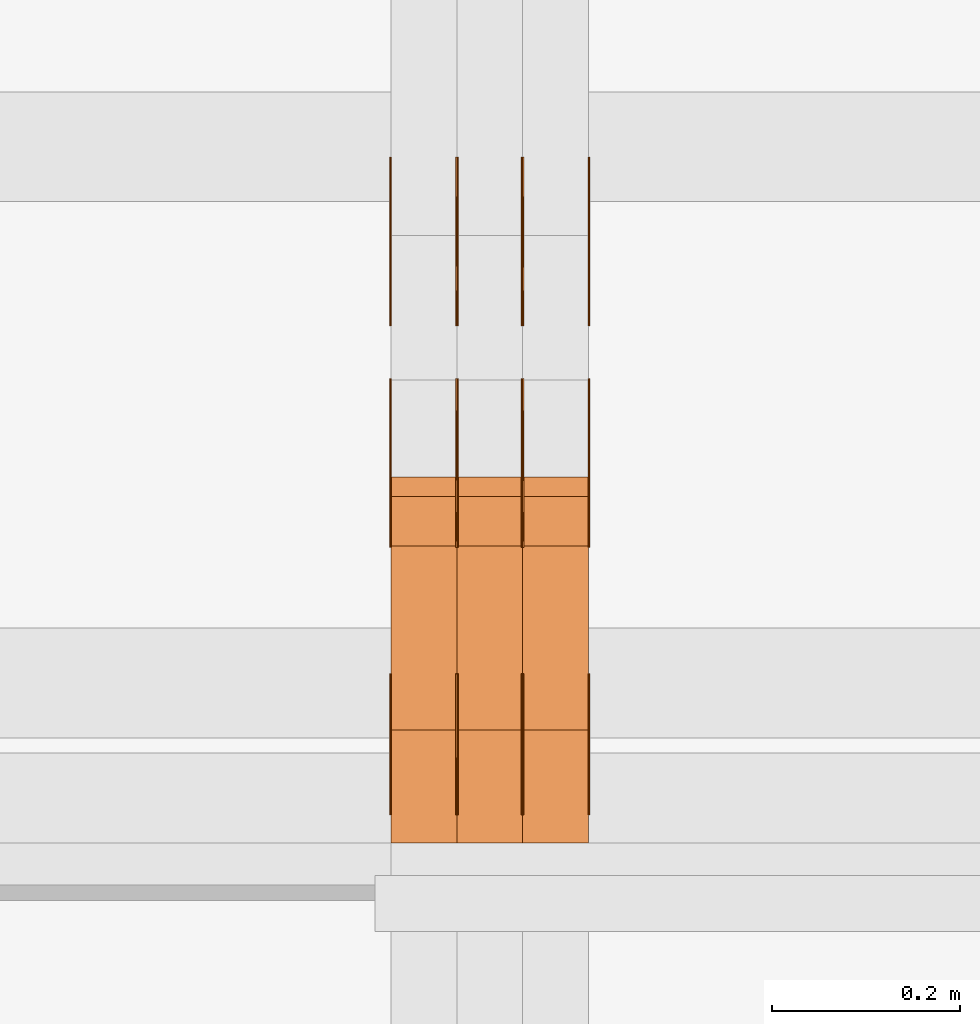
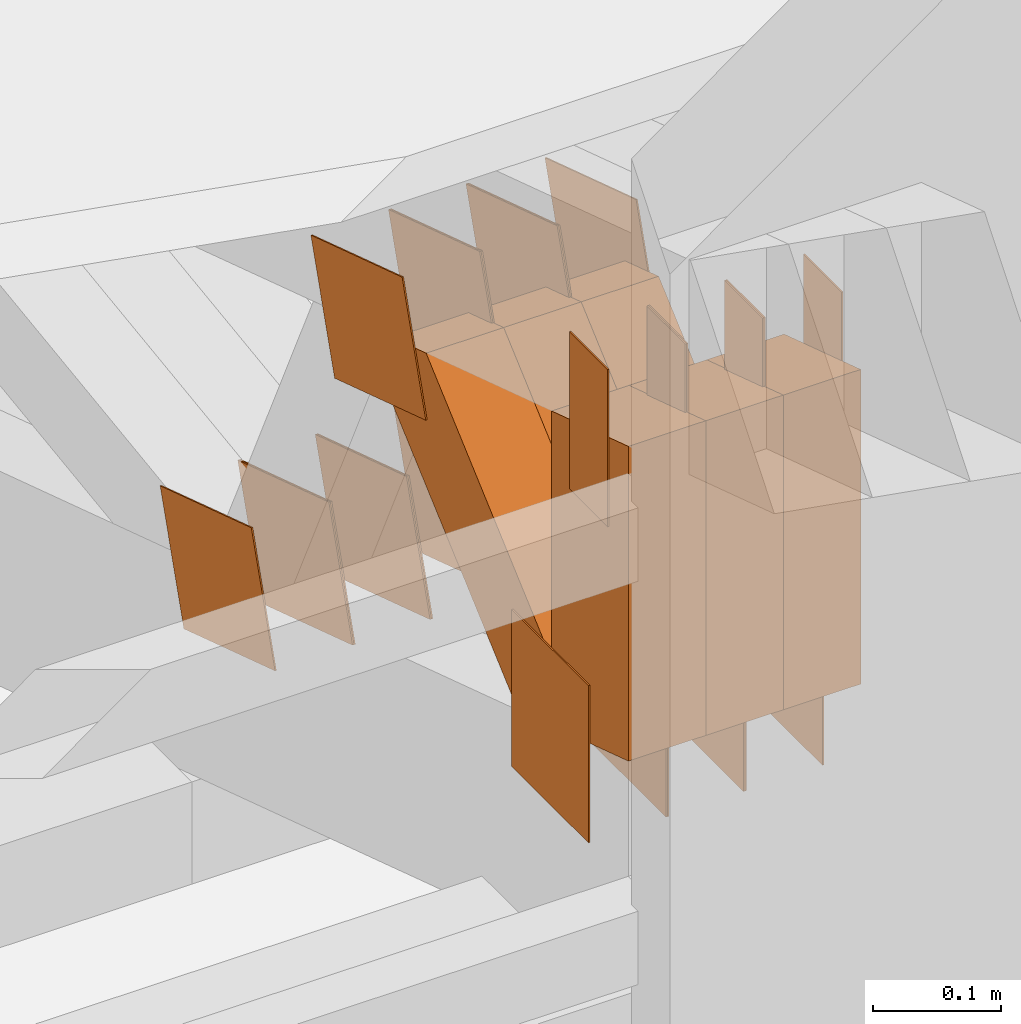
# One storey, part 161 of 385: 30 proxies.
"""IFC2X3 building model written with IfcOpenShell, lengths in millimetres."""

import ifcopenshell
import ifcopenshell.guid

model = None  # the IFC model being written
_history = None  # IfcOwnerHistory: only IFC2X3 demands one
_inside = {}  # id of a spatial element -> (the spatial element, [elements in it])
_under = {}  # id of a project, library or spatial element -> (it, [spatial elements below it])
_declared = {}  # id of a project -> (the project, [libraries it declares])
_typed = {}  # id of a type object -> (the type object, [elements of that type])
_made_of = {}  # id of a material, layer set ... -> (it, [elements and type objects made of it])


def new_model(schema):
    """Start an empty IFC model of exactly this schema.

    Asked for "IFC4X3", IfcOpenShell would pick the latest addendum, in which some entities
    have other attributes; the version numbers below select the first issue.
    IFC2X3 requires an IfcOwnerHistory on every rooted entity: one is made here for all.
    """
    global model, _history
    if schema == "IFC4X3":
        model = ifcopenshell.file(schema_version=(4, 3, 0, 0))
    else:
        model = ifcopenshell.file(schema=schema)
    _inside.clear()
    _under.clear()
    _declared.clear()
    _typed.clear()
    _made_of.clear()
    _history = None
    if model.schema == "IFC2X3":
        org = make("IfcOrganization", Name="unknown")
        user = make(
            "IfcPersonAndOrganization",
            ThePerson=make("IfcPerson", FamilyName="unknown"),
            TheOrganization=org,
        )
        app = make(
            "IfcApplication",
            ApplicationDeveloper=org,
            Version="unknown",
            ApplicationFullName="unknown",
            ApplicationIdentifier="unknown",
        )
        _history = make(
            "IfcOwnerHistory",
            OwningUser=user,
            OwningApplication=app,
            ChangeAction="ADDED",
            CreationDate=0,
        )
    return model


def make(cls, **values):
    """One entity of the class cls with the attributes given. An attribute that is None is left unset."""
    return model.create_entity(
        cls, **{name: value for name, value in values.items() if value is not None}
    )


def entity(cls, *values):
    """Any entity or typed value of the class cls, its attributes in the order of the schema. None: left unset."""
    e = model.create_entity(cls)
    for i, value in enumerate(values):
        if value is not None:
            e[i] = value
    return e


def rooted(cls, **values):
    """An entity with a GlobalId (a new one), such as an element, a storey or a relation."""
    return make(cls, GlobalId=ifcopenshell.guid.new(), OwnerHistory=_history, **values)


def si_unit(unit_type, name, prefix=None):
    """IfcSIUnit, for example si_unit("LENGTHUNIT", "METRE", prefix="MILLI")."""
    return make("IfcSIUnit", UnitType=unit_type, Prefix=prefix, Name=name)


def converted_unit(unit_type, name, factor, base, dimensions=None, offset=None):
    """IfcConversionBasedUnit, such as the inch: factor (a typed value) times the base unit."""
    return make(
        "IfcConversionBasedUnit"
        if offset is None
        else "IfcConversionBasedUnitWithOffset",
        ConversionOffset=offset,
        Dimensions=None
        if dimensions is None
        else entity("IfcDimensionalExponents", *dimensions),
        UnitType=unit_type,
        Name=name,
        ConversionFactor=make(
            "IfcMeasureWithUnit", ValueComponent=factor, UnitComponent=base
        ),
    )


def derived_unit(unit_type, elements):
    """IfcDerivedUnit: a product of units, each with its exponent."""
    return make(
        "IfcDerivedUnit",
        Elements=[
            make("IfcDerivedUnitElement", Unit=unit, Exponent=power)
            for unit, power in elements
        ],
        UnitType=unit_type,
    )


def assignment(units):
    """IfcUnitAssignment: the units of a project."""
    return None if units is None else make("IfcUnitAssignment", Units=units)


def point(xyz):
    """IfcCartesianPoint."""
    return None if xyz is None else make("IfcCartesianPoint", Coordinates=xyz)


def direction(xyz):
    """IfcDirection."""
    return None if xyz is None else make("IfcDirection", DirectionRatios=xyz)


def frame(location, z_axis=None, x_axis=None):
    """IfcAxis2Placement3D, a coordinate frame: its origin and axes. An axis left out is left unset."""
    return make(
        "IfcAxis2Placement3D",
        Location=point(location),
        Axis=direction(z_axis),
        RefDirection=direction(x_axis),
    )


def frame_2d(location, x_axis=None):
    """IfcAxis2Placement2D, a coordinate frame in the plane: its origin and x axis."""
    return make(
        "IfcAxis2Placement2D", Location=point(location), RefDirection=direction(x_axis)
    )


def origin():
    """The frame at (0, 0, 0) with its axes left unset."""
    return frame((0.0, 0.0, 0.0))


def origin_2d_with_axis():
    """The frame at (0, 0) in the plane with the x axis (1, 0) written out."""
    return frame_2d((0.0, 0.0), x_axis=(1.0, 0.0))


def place(relative_to, where):
    """IfcLocalPlacement: puts the frame where relative to a parent placement (None: the world)."""
    return make(
        "IfcLocalPlacement", PlacementRelTo=relative_to, RelativePlacement=where
    )


def context(
    kind, dimensions, precision=None, world=None, true_north=None, identifier=None
):
    """IfcGeometricRepresentationContext, for example the 3D "Model" context."""
    return make(
        "IfcGeometricRepresentationContext",
        ContextIdentifier=identifier,
        ContextType=kind,
        CoordinateSpaceDimension=dimensions,
        Precision=precision,
        WorldCoordinateSystem=world,
        TrueNorth=true_north,
    )


def subcontext(parent, identifier, kind, view, scale=None):
    """IfcGeometricRepresentationSubContext, for example "Body" below "Model"."""
    return make(
        "IfcGeometricRepresentationSubContext",
        ContextIdentifier=identifier,
        ContextType=kind,
        ParentContext=parent,
        TargetScale=scale,
        TargetView=view,
    )


def project(units=None, contexts=None):
    """IfcProject with its units and contexts."""
    return rooted(
        "IfcProject",
        Name="project",
        RepresentationContexts=contexts,
        UnitsInContext=assignment(units),
    )


def spatial(cls, under=None, at=None, **own):
    """A site, building, storey or space (cls), placed at a placement, below another one or the project."""
    s = rooted(cls, ObjectPlacement=at, **own)
    if under is not None:
        _under.setdefault(under.id(), (under, []))[1].append(s)
    return s


def polyline(points):
    """IfcPolyline through the points."""
    return make("IfcPolyline", Points=[point(p) for p in points])


def profile(cls, at=None, kind="AREA", **sizes):
    """A parametric profile (cls). Its sizes go by their IFC names, for example OverallWidth=200.0."""
    return make(cls, ProfileType=kind, Position=at, **sizes)


def rectangle(**sizes):
    """IfcRectangleProfileDef."""
    return profile("IfcRectangleProfileDef", **sizes)


def outline(outer, holes=None, kind="AREA"):
    """IfcArbitraryClosedProfileDef: a profile drawn as a closed curve; with holes, ...WithVoids."""
    if holes is None:
        return make("IfcArbitraryClosedProfileDef", ProfileType=kind, OuterCurve=outer)
    return make(
        "IfcArbitraryProfileDefWithVoids",
        ProfileType=kind,
        OuterCurve=outer,
        InnerCurves=holes,
    )


def extrude(swept, where, along, depth):
    """IfcExtrudedAreaSolid: the profile swept, set in the frame where, extruded along a direction by depth."""
    return make(
        "IfcExtrudedAreaSolid",
        SweptArea=swept,
        Position=where,
        ExtrudedDirection=direction(along),
        Depth=depth,
    )


def shape(context_of_items, identifier, shape_type, items):
    """IfcShapeRepresentation: the items that make up one representation, for example the "Body"."""
    return make(
        "IfcShapeRepresentation",
        ContextOfItems=context_of_items,
        RepresentationIdentifier=identifier,
        RepresentationType=shape_type,
        Items=items,
    )


def source(mapping_origin, context_of_items, identifier, shape_type, items):
    """IfcRepresentationMap: a shape defined once, which mapped items show again and again."""
    return make(
        "IfcRepresentationMap",
        MappingOrigin=mapping_origin,
        MappedRepresentation=shape(context_of_items, identifier, shape_type, items),
    )


def transform(
    local_origin,
    x_axis=None,
    y_axis=None,
    z_axis=None,
    scale=None,
    scale2=None,
    scale3=None,
    uniform=True,
):
    """IfcCartesianTransformationOperator3D, or its non-uniform kind. x_axis, y_axis, z_axis: its Axis1, 2, 3."""
    if uniform:
        return make(
            "IfcCartesianTransformationOperator3D",
            Axis1=direction(x_axis),
            Axis2=direction(y_axis),
            LocalOrigin=point(local_origin),
            Scale=scale,
            Axis3=direction(z_axis),
        )
    return make(
        "IfcCartesianTransformationOperator3DnonUniform",
        Axis1=direction(x_axis),
        Axis2=direction(y_axis),
        LocalOrigin=point(local_origin),
        Scale=scale,
        Axis3=direction(z_axis),
        Scale2=scale2,
        Scale3=scale3,
    )


def mapped(mapping_source, mapping_target):
    """IfcMappedItem: shows the shape of a source again, moved by a transform."""
    return make(
        "IfcMappedItem", MappingSource=mapping_source, MappingTarget=mapping_target
    )


def material(Name=None, Category=None):
    """IfcMaterial."""
    return make("IfcMaterial", Name=Name, Category=Category)


def made_of(thing, what):
    """Note that an element or type object is made of a material, layer set ...; save() writes the relation."""
    if what is not None:
        _made_of.setdefault(what.id(), (what, []))[1].append(thing)
    return thing


def type_object(cls, material=None, **own):
    """A type object (cls), such as IfcWallType, which elements share."""
    return made_of(rooted(cls, **own), material)


def type_shapes(of_type, sources):
    """Give a type object the sources (RepresentationMaps) that its elements show as mapped items."""
    of_type.RepresentationMaps = sources


def element(
    cls,
    number,
    at=None,
    inside=None,
    cuts=None,
    type_object=None,
    material=None,
    context=None,
    identifier="Body",
    shape_type=None,
    held_by="IfcProductDefinitionShape",
    body=None,
    shapes=None,
    **own,
):
    """One element of the class cls, such as IfcWall. Its Tag is "e" and its number.

    at: its placement. inside: the storey or other place that contains it. cuts: it is an
    opening in that element (IfcRelVoidsElement). A single representation is given by context,
    identifier, shape_type and body (its items); several are given by shapes. held_by: the class
    of the entity that holds the representations. save() writes the other relations.
    """
    e = rooted(cls, Tag="e%d" % number, ObjectPlacement=at, **own)
    if body is not None:
        shapes = [shape(context, identifier, shape_type, body)]
    if shapes is not None:
        e.Representation = make(held_by, Representations=shapes)
    if inside is not None:
        _inside.setdefault(inside.id(), (inside, []))[1].append(e)
    if cuts is not None:
        rooted(
            "IfcRelVoidsElement", RelatingBuildingElement=cuts, RelatedOpeningElement=e
        )
    if type_object is not None:
        _typed.setdefault(type_object.id(), (type_object, []))[1].append(e)
    return made_of(e, material)


def aggregate(whole, parts):
    """IfcRelAggregates: a whole, such as a stair, and the parts it consists of."""
    return rooted("IfcRelAggregates", RelatingObject=whole, RelatedObjects=parts)


def save(model, path):
    """Write the relations noted so far, then the file.

    IfcRelAggregates (storeys below a building ...), IfcRelContainedInSpatialStructure (elements
    in a storey), IfcRelDefinesByType, IfcRelAssociatesMaterial and IfcRelDeclares: one each for
    every whole, place, type object, material and project.
    """
    for whole, parts in _under.values():
        aggregate(whole, parts)
    for where, things in _inside.values():
        rooted(
            "IfcRelContainedInSpatialStructure",
            RelatedElements=things,
            RelatingStructure=where,
        )
    for kind, things in _typed.values():
        rooted("IfcRelDefinesByType", RelatedObjects=things, RelatingType=kind)
    for what, things in _made_of.values():
        rooted("IfcRelAssociatesMaterial", RelatedObjects=things, RelatingMaterial=what)
    for by, libraries in _declared.values():
        rooted("IfcRelDeclares", RelatingContext=by, RelatedDefinitions=libraries)
    model.write(path)


model = new_model("IFC2X3")

# Units and contexts
model_context = context("Model", 3, precision=0.01, world=origin(), true_north=direction((6.12303176911189e-17, 1.0)))
body_context = subcontext(model_context, "Body", "Model", "MODEL_VIEW")
ifc_project = project(units=[si_unit("LENGTHUNIT", "METRE", prefix="MILLI"), si_unit("AREAUNIT", "SQUARE_METRE"), si_unit("VOLUMEUNIT", "CUBIC_METRE"), converted_unit("PLANEANGLEUNIT", "DEGREE", entity("IfcRatioMeasure", 0.0174532925199433), si_unit("PLANEANGLEUNIT", "RADIAN"), dimensions=[0, 0, 0, 0, 0, 0, 0]), si_unit("MASSUNIT", "GRAM", prefix="KILO"), derived_unit("MASSDENSITYUNIT", [(si_unit("MASSUNIT", "GRAM", prefix="KILO"), 1), (si_unit("LENGTHUNIT", "METRE"), -3)]), si_unit("TIMEUNIT", "SECOND"), si_unit("FREQUENCYUNIT", "HERTZ"), si_unit("THERMODYNAMICTEMPERATUREUNIT", "DEGREE_CELSIUS"), derived_unit("THERMALTRANSMITTANCEUNIT", [(si_unit("MASSUNIT", "GRAM", prefix="KILO"), 1), (si_unit("THERMODYNAMICTEMPERATUREUNIT", "KELVIN"), -1), (si_unit("TIMEUNIT", "SECOND"), -3)]), derived_unit("VOLUMETRICFLOWRATEUNIT", [(si_unit("LENGTHUNIT", "METRE"), 3), (si_unit("TIMEUNIT", "SECOND"), -1)]), si_unit("ELECTRICCURRENTUNIT", "AMPERE"), si_unit("ELECTRICVOLTAGEUNIT", "VOLT"), si_unit("POWERUNIT", "WATT"), si_unit("FORCEUNIT", "NEWTON", prefix="KILO"), si_unit("ILLUMINANCEUNIT", "LUX"), si_unit("LUMINOUSFLUXUNIT", "LUMEN"), si_unit("LUMINOUSINTENSITYUNIT", "CANDELA"), derived_unit("USERDEFINED", [(si_unit("MASSUNIT", "GRAM", prefix="KILO"), -1), (si_unit("LENGTHUNIT", "METRE"), -2), (si_unit("TIMEUNIT", "SECOND"), 3), (si_unit("LUMINOUSFLUXUNIT", "LUMEN"), 1)]), derived_unit("LINEARVELOCITYUNIT", [(si_unit("LENGTHUNIT", "METRE"), 1), (si_unit("TIMEUNIT", "SECOND"), -1)]), si_unit("PRESSUREUNIT", "PASCAL"), derived_unit("USERDEFINED", [(si_unit("LENGTHUNIT", "METRE"), -2), (si_unit("MASSUNIT", "GRAM", prefix="KILO"), 1), (si_unit("TIMEUNIT", "SECOND"), -2)])], contexts=[model_context])

# Site, building, storey
site_placement = place(None, origin())
site = spatial("IfcSite", under=ifc_project, at=site_placement, CompositionType="ELEMENT")
building_placement = place(site_placement, origin())
building = spatial("IfcBuilding", under=site, at=building_placement, CompositionType="ELEMENT")
storey_placement = place(building_placement, origin())
storey = spatial("IfcBuildingStorey", under=building, at=storey_placement, Name="Default", CompositionType="ELEMENT", Elevation=0.0)

# Proxies
ifc_material_1 = material(Name="IfcSurfaceStyle #308674")
building_element_proxy_type_1 = type_object("IfcBuildingElementProxyType", PredefinedType="NOTDEFINED", material=ifc_material_1)
shared_shape_1 = source(origin(), body_context, "Body", "SweptSolid", [
    extrude(rectangle(XDim=150.0, YDim=120.0, at=origin_2d_with_axis()), frame((75.0, 60.0, 0.0), z_axis=(0.0, 0.0, 1.0), x_axis=(-1.0, 0.0, 0.0)), (0.0, 0.0, 1.0), 1.3),
])
type_shapes(building_element_proxy_type_1, [shared_shape_1])
proxy_1_placement = place(building_placement, frame((24386.3, 15840.0, 3652.70166015625), z_axis=(-1.0, 0.0, 0.0), x_axis=(0.0, 0.0, -1.0)))
element("IfcBuildingElementProxy", 1, at=proxy_1_placement, inside=storey, type_object=building_element_proxy_type_1, material=ifc_material_1, context=body_context, shape_type="MappedRepresentation", body=[
    mapped(shared_shape_1, transform((0.0, 0.0, 0.0), scale=1.0)),
])
ifc_material_2 = material(Name="IfcSurfaceStyle #308617")
building_element_proxy_type_2 = type_object("IfcBuildingElementProxyType", PredefinedType="NOTDEFINED", material=ifc_material_2)
shared_shape_2 = source(origin(), body_context, "Body", "SweptSolid", [
    extrude(rectangle(XDim=150.0, YDim=120.0, at=origin_2d_with_axis()), frame((75.0, 60.0, 0.0), z_axis=(0.0, 0.0, 1.0), x_axis=(-1.0, 0.0, 0.0)), (0.0, 0.0, 1.0), 1.3),
])
type_shapes(building_element_proxy_type_2, [shared_shape_2])
proxy_2_placement = place(building_placement, frame((24315.0, 15840.0, 3652.70166015625), z_axis=(-1.0, 0.0, 0.0), x_axis=(0.0, 0.0, -1.0)))
element("IfcBuildingElementProxy", 2, at=proxy_2_placement, inside=storey, type_object=building_element_proxy_type_2, material=ifc_material_2, context=body_context, shape_type="MappedRepresentation", body=[
    mapped(shared_shape_2, transform((0.0, 0.0, 0.0), scale=1.0)),
])
ifc_material_3 = material(Name="IfcSurfaceStyle #308560")
building_element_proxy_type_3 = type_object("IfcBuildingElementProxyType", PredefinedType="NOTDEFINED", material=ifc_material_3)
shared_shape_3 = source(origin(), body_context, "Body", "SweptSolid", [
    extrude(rectangle(XDim=150.0, YDim=120.0, at=origin_2d_with_axis()), frame((75.0, 60.0, 0.0), z_axis=(0.0, 0.0, 1.0), x_axis=(-1.0, 0.0, 0.0)), (0.0, 0.0, 1.0), 1.3),
])
type_shapes(building_element_proxy_type_3, [shared_shape_3])
proxy_3_placement = place(building_placement, frame((24316.3, 15840.0, 3652.70166015625), z_axis=(-1.0, 0.0, 0.0), x_axis=(0.0, 0.0, -1.0)))
element("IfcBuildingElementProxy", 3, at=proxy_3_placement, inside=storey, type_object=building_element_proxy_type_3, material=ifc_material_3, context=body_context, shape_type="MappedRepresentation", body=[
    mapped(shared_shape_3, transform((0.0, 0.0, 0.0), scale=1.0)),
])
ifc_material_4 = material(Name="IfcSurfaceStyle #308503")
building_element_proxy_type_4 = type_object("IfcBuildingElementProxyType", PredefinedType="NOTDEFINED", material=ifc_material_4)
shared_shape_4 = source(origin(), body_context, "Body", "SweptSolid", [
    extrude(rectangle(XDim=150.0, YDim=120.0, at=origin_2d_with_axis()), frame((75.0, 60.0, 0.0), z_axis=(0.0, 0.0, 1.0), x_axis=(-1.0, 0.0, 0.0)), (0.0, 0.0, 1.0), 1.29999999999999),
])
type_shapes(building_element_proxy_type_4, [shared_shape_4])
proxy_4_placement = place(building_placement, frame((24245.0, 15840.0, 3652.70166015625), z_axis=(-1.0, 0.0, 0.0), x_axis=(0.0, 0.0, -1.0)))
element("IfcBuildingElementProxy", 4, at=proxy_4_placement, inside=storey, type_object=building_element_proxy_type_4, material=ifc_material_4, context=body_context, shape_type="MappedRepresentation", body=[
    mapped(shared_shape_4, transform((0.0, 0.0, 0.0), scale=1.0)),
])
ifc_material_5 = material(Name="IfcSurfaceStyle #308446")
building_element_proxy_type_5 = type_object("IfcBuildingElementProxyType", PredefinedType="NOTDEFINED", material=ifc_material_5)
shared_shape_5 = source(origin(), body_context, "Body", "SweptSolid", [
    extrude(rectangle(XDim=150.0, YDim=120.0, at=origin_2d_with_axis()), frame((75.0, 60.0, 0.0), z_axis=(0.0, 0.0, 1.0), x_axis=(-1.0, 0.0, 0.0)), (0.0, 0.0, 1.0), 1.29999999999999),
])
type_shapes(building_element_proxy_type_5, [shared_shape_5])
proxy_5_placement = place(building_placement, frame((24246.3, 15840.0, 3652.70166015625), z_axis=(-1.0, 0.0, 0.0), x_axis=(0.0, 0.0, -1.0)))
element("IfcBuildingElementProxy", 5, at=proxy_5_placement, inside=storey, type_object=building_element_proxy_type_5, material=ifc_material_5, context=body_context, shape_type="MappedRepresentation", body=[
    mapped(shared_shape_5, transform((0.0, 0.0, 0.0), scale=1.0)),
])
ifc_material_6 = material(Name="IfcSurfaceStyle #308389")
building_element_proxy_type_6 = type_object("IfcBuildingElementProxyType", PredefinedType="NOTDEFINED", material=ifc_material_6)
shared_shape_6 = source(origin(), body_context, "Body", "SweptSolid", [
    extrude(rectangle(XDim=150.0, YDim=120.0, at=origin_2d_with_axis()), frame((75.0, 60.0, 0.0), z_axis=(0.0, 0.0, 1.0), x_axis=(-1.0, 0.0, 0.0)), (0.0, 0.0, 1.0), 1.29999999999999),
])
type_shapes(building_element_proxy_type_6, [shared_shape_6])
proxy_6_placement = place(building_placement, frame((24175.0, 15840.0, 3652.70166015625), z_axis=(-1.0, 0.0, 0.0), x_axis=(0.0, 0.0, -1.0)))
element("IfcBuildingElementProxy", 6, at=proxy_6_placement, inside=storey, type_object=building_element_proxy_type_6, material=ifc_material_6, context=body_context, shape_type="MappedRepresentation", body=[
    mapped(shared_shape_6, transform((0.0, 0.0, 0.0), scale=1.0)),
])
ifc_material_7 = material(Name="IfcSurfaceStyle #308332")
building_element_proxy_type_7 = type_object("IfcBuildingElementProxyType", PredefinedType="NOTDEFINED", material=ifc_material_7)
shared_shape_7 = source(origin(), body_context, "Body", "SweptSolid", [
    extrude(outline(polyline([(-74.9998605591118, -59.9999264677601), (74.9998754286171, -59.9999264677601), (74.9998605591118, 59.9999264677602), (-74.9998754286171, 59.9999264677602), (-74.9998605591118, -59.9999264677601)])), frame((74.9998754286171, 60.0000503992849, 0.0), z_axis=(0.0, 0.0, 1.0), x_axis=(-1.0, 0.0, 0.0)), (0.0, 0.0, 1.0), 1.3),
])
type_shapes(building_element_proxy_type_7, [shared_shape_7])
proxy_7_placement = place(building_placement, frame((24386.3, 16352.8320303235, 3323.23212676408), z_axis=(-1.0, 0.0, 0.0), x_axis=(0.0, -0.951056516295124, 0.309016994375039)))
element("IfcBuildingElementProxy", 7, at=proxy_7_placement, inside=storey, type_object=building_element_proxy_type_7, material=ifc_material_7, context=body_context, shape_type="MappedRepresentation", body=[
    mapped(shared_shape_7, transform((0.0, 0.0, 0.0), scale=1.0)),
])
ifc_material_8 = material(Name="IfcSurfaceStyle #308275")
building_element_proxy_type_8 = type_object("IfcBuildingElementProxyType", PredefinedType="NOTDEFINED", material=ifc_material_8)
shared_shape_8 = source(origin(), body_context, "Body", "SweptSolid", [
    extrude(outline(polyline([(-74.9998605591118, -59.9999264677601), (74.9998754286171, -59.9999264677601), (74.9998605591118, 59.9999264677602), (-74.9998754286171, 59.9999264677602), (-74.9998605591118, -59.9999264677601)])), frame((74.9998754286171, 60.0000503992849, 0.0), z_axis=(0.0, 0.0, 1.0), x_axis=(-1.0, 0.0, 0.0)), (0.0, 0.0, 1.0), 1.3),
])
type_shapes(building_element_proxy_type_8, [shared_shape_8])
proxy_8_placement = place(building_placement, frame((24315.0, 16352.8320303235, 3323.23212676408), z_axis=(-1.0, 0.0, 0.0), x_axis=(0.0, -0.951056516295124, 0.309016994375039)))
element("IfcBuildingElementProxy", 8, at=proxy_8_placement, inside=storey, type_object=building_element_proxy_type_8, material=ifc_material_8, context=body_context, shape_type="MappedRepresentation", body=[
    mapped(shared_shape_8, transform((0.0, 0.0, 0.0), scale=1.0)),
])
ifc_material_9 = material(Name="IfcSurfaceStyle #308218")
building_element_proxy_type_9 = type_object("IfcBuildingElementProxyType", PredefinedType="NOTDEFINED", material=ifc_material_9)
shared_shape_9 = source(origin(), body_context, "Body", "SweptSolid", [
    extrude(outline(polyline([(-74.9998605591118, -59.9999264677601), (74.9998754286171, -59.9999264677601), (74.9998605591118, 59.9999264677602), (-74.9998754286171, 59.9999264677602), (-74.9998605591118, -59.9999264677601)])), frame((74.9998754286171, 60.0000503992849, 0.0), z_axis=(0.0, 0.0, 1.0), x_axis=(-1.0, 0.0, 0.0)), (0.0, 0.0, 1.0), 1.3),
])
type_shapes(building_element_proxy_type_9, [shared_shape_9])
proxy_9_placement = place(building_placement, frame((24316.3, 16352.8320303235, 3323.23212676408), z_axis=(-1.0, 0.0, 0.0), x_axis=(0.0, -0.951056516295124, 0.309016994375039)))
element("IfcBuildingElementProxy", 9, at=proxy_9_placement, inside=storey, type_object=building_element_proxy_type_9, material=ifc_material_9, context=body_context, shape_type="MappedRepresentation", body=[
    mapped(shared_shape_9, transform((0.0, 0.0, 0.0), scale=1.0)),
])
ifc_material_10 = material(Name="IfcSurfaceStyle #308161")
building_element_proxy_type_10 = type_object("IfcBuildingElementProxyType", PredefinedType="NOTDEFINED", material=ifc_material_10)
shared_shape_10 = source(origin(), body_context, "Body", "SweptSolid", [
    extrude(outline(polyline([(-74.9998605591118, -59.9999264677601), (74.9998754286171, -59.9999264677601), (74.9998605591118, 59.9999264677602), (-74.9998754286171, 59.9999264677602), (-74.9998605591118, -59.9999264677601)])), frame((74.9998754286171, 60.0000503992849, 0.0), z_axis=(0.0, 0.0, 1.0), x_axis=(-1.0, 0.0, 0.0)), (0.0, 0.0, 1.0), 1.29999999999999),
])
type_shapes(building_element_proxy_type_10, [shared_shape_10])
proxy_10_placement = place(building_placement, frame((24245.0, 16352.8320303235, 3323.23212676408), z_axis=(-1.0, 0.0, 0.0), x_axis=(0.0, -0.951056516295124, 0.309016994375039)))
element("IfcBuildingElementProxy", 10, at=proxy_10_placement, inside=storey, type_object=building_element_proxy_type_10, material=ifc_material_10, context=body_context, shape_type="MappedRepresentation", body=[
    mapped(shared_shape_10, transform((0.0, 0.0, 0.0), scale=1.0)),
])
ifc_material_11 = material(Name="IfcSurfaceStyle #308104")
building_element_proxy_type_11 = type_object("IfcBuildingElementProxyType", PredefinedType="NOTDEFINED", material=ifc_material_11)
shared_shape_11 = source(origin(), body_context, "Body", "SweptSolid", [
    extrude(outline(polyline([(-74.9998605591118, -59.9999264677601), (74.9998754286171, -59.9999264677601), (74.9998605591118, 59.9999264677602), (-74.9998754286171, 59.9999264677602), (-74.9998605591118, -59.9999264677601)])), frame((74.9998754286171, 60.0000503992849, 0.0), z_axis=(0.0, 0.0, 1.0), x_axis=(-1.0, 0.0, 0.0)), (0.0, 0.0, 1.0), 1.29999999999999),
])
type_shapes(building_element_proxy_type_11, [shared_shape_11])
proxy_11_placement = place(building_placement, frame((24246.3, 16352.8320303235, 3323.23212676408), z_axis=(-1.0, 0.0, 0.0), x_axis=(0.0, -0.951056516295124, 0.309016994375039)))
element("IfcBuildingElementProxy", 11, at=proxy_11_placement, inside=storey, type_object=building_element_proxy_type_11, material=ifc_material_11, context=body_context, shape_type="MappedRepresentation", body=[
    mapped(shared_shape_11, transform((0.0, 0.0, 0.0), scale=1.0)),
])
ifc_material_12 = material(Name="IfcSurfaceStyle #308047")
building_element_proxy_type_12 = type_object("IfcBuildingElementProxyType", PredefinedType="NOTDEFINED", material=ifc_material_12)
shared_shape_12 = source(origin(), body_context, "Body", "SweptSolid", [
    extrude(outline(polyline([(-74.9998605591118, -59.9999264677601), (74.9998754286171, -59.9999264677601), (74.9998605591118, 59.9999264677602), (-74.9998754286171, 59.9999264677602), (-74.9998605591118, -59.9999264677601)])), frame((74.9998754286171, 60.0000503992849, 0.0), z_axis=(0.0, 0.0, 1.0), x_axis=(-1.0, 0.0, 0.0)), (0.0, 0.0, 1.0), 1.29999999999999),
])
type_shapes(building_element_proxy_type_12, [shared_shape_12])
proxy_12_placement = place(building_placement, frame((24175.0, 16352.8320303235, 3323.23212676408), z_axis=(-1.0, 0.0, 0.0), x_axis=(0.0, -0.951056516295124, 0.309016994375039)))
element("IfcBuildingElementProxy", 12, at=proxy_12_placement, inside=storey, type_object=building_element_proxy_type_12, material=ifc_material_12, context=body_context, shape_type="MappedRepresentation", body=[
    mapped(shared_shape_12, transform((0.0, 0.0, 0.0), scale=1.0)),
])
ifc_material_13 = material(Name="IfcSurfaceStyle #303886")
building_element_proxy_type_13 = type_object("IfcBuildingElementProxyType", PredefinedType="NOTDEFINED", material=ifc_material_13)
shared_shape_13 = source(origin(), body_context, "Body", "SweptSolid", [
    extrude(outline(polyline([(-75.0003249421702, -60.0000773549573), (75.0003398116874, -60.0000773549573), (75.0003249421711, 60.0000773549573), (-75.0003398116883, 60.0000773549573), (-75.0003249421702, -60.0000773549573)])), frame((75.0003398116874, 60.0000773549573, 0.0), z_axis=(0.0, 0.0, 1.0), x_axis=(-1.0, 0.0, 0.0)), (0.0, 0.0, 1.0), 1.3),
])
type_shapes(building_element_proxy_type_13, [shared_shape_13])
proxy_13_placement = place(building_placement, frame((24386.3, 16117.0849050545, 3705.49074668796), z_axis=(-1.0, 0.0, 0.0), x_axis=(0.0, -0.951056516295154, 0.309016994374948)))
element("IfcBuildingElementProxy", 13, at=proxy_13_placement, inside=storey, type_object=building_element_proxy_type_13, material=ifc_material_13, context=body_context, shape_type="MappedRepresentation", body=[
    mapped(shared_shape_13, transform((0.0, 0.0, 0.0), scale=1.0)),
])
ifc_material_14 = material(Name="IfcSurfaceStyle #303829")
building_element_proxy_type_14 = type_object("IfcBuildingElementProxyType", PredefinedType="NOTDEFINED", material=ifc_material_14)
shared_shape_14 = source(origin(), body_context, "Body", "SweptSolid", [
    extrude(outline(polyline([(-75.0003249421702, -60.0000773549573), (75.0003398116874, -60.0000773549573), (75.0003249421711, 60.0000773549573), (-75.0003398116883, 60.0000773549573), (-75.0003249421702, -60.0000773549573)])), frame((75.0003398116874, 60.0000773549573, 0.0), z_axis=(0.0, 0.0, 1.0), x_axis=(-1.0, 0.0, 0.0)), (0.0, 0.0, 1.0), 1.3),
])
type_shapes(building_element_proxy_type_14, [shared_shape_14])
proxy_14_placement = place(building_placement, frame((24315.0, 16117.0849050545, 3705.49074668796), z_axis=(-1.0, 0.0, 0.0), x_axis=(0.0, -0.951056516295154, 0.309016994374948)))
element("IfcBuildingElementProxy", 14, at=proxy_14_placement, inside=storey, type_object=building_element_proxy_type_14, material=ifc_material_14, context=body_context, shape_type="MappedRepresentation", body=[
    mapped(shared_shape_14, transform((0.0, 0.0, 0.0), scale=1.0)),
])
ifc_material_15 = material(Name="IfcSurfaceStyle #303772")
building_element_proxy_type_15 = type_object("IfcBuildingElementProxyType", PredefinedType="NOTDEFINED", material=ifc_material_15)
shared_shape_15 = source(origin(), body_context, "Body", "SweptSolid", [
    extrude(outline(polyline([(-75.0003249421702, -60.0000773549573), (75.0003398116874, -60.0000773549573), (75.0003249421711, 60.0000773549573), (-75.0003398116883, 60.0000773549573), (-75.0003249421702, -60.0000773549573)])), frame((75.0003398116874, 60.0000773549573, 0.0), z_axis=(0.0, 0.0, 1.0), x_axis=(-1.0, 0.0, 0.0)), (0.0, 0.0, 1.0), 1.3),
])
type_shapes(building_element_proxy_type_15, [shared_shape_15])
proxy_15_placement = place(building_placement, frame((24316.3, 16117.0849050545, 3705.49074668796), z_axis=(-1.0, 0.0, 0.0), x_axis=(0.0, -0.951056516295154, 0.309016994374948)))
element("IfcBuildingElementProxy", 15, at=proxy_15_placement, inside=storey, type_object=building_element_proxy_type_15, material=ifc_material_15, context=body_context, shape_type="MappedRepresentation", body=[
    mapped(shared_shape_15, transform((0.0, 0.0, 0.0), scale=1.0)),
])
ifc_material_16 = material(Name="IfcSurfaceStyle #303715")
building_element_proxy_type_16 = type_object("IfcBuildingElementProxyType", PredefinedType="NOTDEFINED", material=ifc_material_16)
shared_shape_16 = source(origin(), body_context, "Body", "SweptSolid", [
    extrude(outline(polyline([(-75.0003249421702, -60.0000773549573), (75.0003398116874, -60.0000773549573), (75.0003249421711, 60.0000773549573), (-75.0003398116883, 60.0000773549573), (-75.0003249421702, -60.0000773549573)])), frame((75.0003398116874, 60.0000773549573, 0.0), z_axis=(0.0, 0.0, 1.0), x_axis=(-1.0, 0.0, 0.0)), (0.0, 0.0, 1.0), 1.29999999999999),
])
type_shapes(building_element_proxy_type_16, [shared_shape_16])
proxy_16_placement = place(building_placement, frame((24245.0, 16117.0849050545, 3705.49074668796), z_axis=(-1.0, 0.0, 0.0), x_axis=(0.0, -0.951056516295154, 0.309016994374948)))
element("IfcBuildingElementProxy", 16, at=proxy_16_placement, inside=storey, type_object=building_element_proxy_type_16, material=ifc_material_16, context=body_context, shape_type="MappedRepresentation", body=[
    mapped(shared_shape_16, transform((0.0, 0.0, 0.0), scale=1.0)),
])
ifc_material_17 = material(Name="IfcSurfaceStyle #303658")
building_element_proxy_type_17 = type_object("IfcBuildingElementProxyType", PredefinedType="NOTDEFINED", material=ifc_material_17)
shared_shape_17 = source(origin(), body_context, "Body", "SweptSolid", [
    extrude(outline(polyline([(-75.0003249421702, -60.0000773549573), (75.0003398116874, -60.0000773549573), (75.0003249421711, 60.0000773549573), (-75.0003398116883, 60.0000773549573), (-75.0003249421702, -60.0000773549573)])), frame((75.0003398116874, 60.0000773549573, 0.0), z_axis=(0.0, 0.0, 1.0), x_axis=(-1.0, 0.0, 0.0)), (0.0, 0.0, 1.0), 1.29999999999999),
])
type_shapes(building_element_proxy_type_17, [shared_shape_17])
proxy_17_placement = place(building_placement, frame((24246.3, 16117.0849050545, 3705.49074668796), z_axis=(-1.0, 0.0, 0.0), x_axis=(0.0, -0.951056516295154, 0.309016994374948)))
element("IfcBuildingElementProxy", 17, at=proxy_17_placement, inside=storey, type_object=building_element_proxy_type_17, material=ifc_material_17, context=body_context, shape_type="MappedRepresentation", body=[
    mapped(shared_shape_17, transform((0.0, 0.0, 0.0), scale=1.0)),
])
ifc_material_18 = material(Name="IfcSurfaceStyle #303601")
building_element_proxy_type_18 = type_object("IfcBuildingElementProxyType", PredefinedType="NOTDEFINED", material=ifc_material_18)
shared_shape_18 = source(origin(), body_context, "Body", "SweptSolid", [
    extrude(outline(polyline([(-75.0003249421702, -60.0000773549573), (75.0003398116874, -60.0000773549573), (75.0003249421711, 60.0000773549573), (-75.0003398116883, 60.0000773549573), (-75.0003249421702, -60.0000773549573)])), frame((75.0003398116874, 60.0000773549573, 0.0), z_axis=(0.0, 0.0, 1.0), x_axis=(-1.0, 0.0, 0.0)), (0.0, 0.0, 1.0), 1.29999999999999),
])
type_shapes(building_element_proxy_type_18, [shared_shape_18])
proxy_18_placement = place(building_placement, frame((24175.0, 16117.0849050545, 3705.49074668796), z_axis=(-1.0, 0.0, 0.0), x_axis=(0.0, -0.951056516295154, 0.309016994374948)))
element("IfcBuildingElementProxy", 18, at=proxy_18_placement, inside=storey, type_object=building_element_proxy_type_18, material=ifc_material_18, context=body_context, shape_type="MappedRepresentation", body=[
    mapped(shared_shape_18, transform((0.0, 0.0, 0.0), scale=1.0)),
])
ifc_material_19 = material(Name="IfcSurfaceStyle #303202")
building_element_proxy_type_19 = type_object("IfcBuildingElementProxyType", PredefinedType="NOTDEFINED", material=ifc_material_19)
shared_shape_19 = source(origin(), body_context, "Body", "SweptSolid", [
    extrude(rectangle(XDim=150.0, YDim=60.0, at=origin_2d_with_axis()), frame((75.0000705696311, 30.0, 0.0), z_axis=(0.0, 0.0, 1.0), x_axis=(-1.0, 0.0, 0.0)), (0.0, 0.0, 1.0), 1.3),
])
type_shapes(building_element_proxy_type_19, [shared_shape_19])
proxy_19_placement = place(building_placement, frame((24386.3, 15750.0, 3972.59919166338), z_axis=(-1.0, 0.0, 0.0), x_axis=(0.0, 0.0, -1.0)))
element("IfcBuildingElementProxy", 19, at=proxy_19_placement, inside=storey, type_object=building_element_proxy_type_19, material=ifc_material_19, context=body_context, shape_type="MappedRepresentation", body=[
    mapped(shared_shape_19, transform((0.0, 0.0, 0.0), scale=1.0)),
])
ifc_material_20 = material(Name="IfcSurfaceStyle #303145")
building_element_proxy_type_20 = type_object("IfcBuildingElementProxyType", PredefinedType="NOTDEFINED", material=ifc_material_20)
shared_shape_20 = source(origin(), body_context, "Body", "SweptSolid", [
    extrude(rectangle(XDim=150.0, YDim=60.0, at=origin_2d_with_axis()), frame((75.0000705696311, 30.0, 0.0), z_axis=(0.0, 0.0, 1.0), x_axis=(-1.0, 0.0, 0.0)), (0.0, 0.0, 1.0), 1.3),
])
type_shapes(building_element_proxy_type_20, [shared_shape_20])
proxy_20_placement = place(building_placement, frame((24315.0, 15750.0, 3972.59919166338), z_axis=(-1.0, 0.0, 0.0), x_axis=(0.0, 0.0, -1.0)))
element("IfcBuildingElementProxy", 20, at=proxy_20_placement, inside=storey, type_object=building_element_proxy_type_20, material=ifc_material_20, context=body_context, shape_type="MappedRepresentation", body=[
    mapped(shared_shape_20, transform((0.0, 0.0, 0.0), scale=1.0)),
])
ifc_material_21 = material(Name="IfcSurfaceStyle #303088")
building_element_proxy_type_21 = type_object("IfcBuildingElementProxyType", PredefinedType="NOTDEFINED", material=ifc_material_21)
shared_shape_21 = source(origin(), body_context, "Body", "SweptSolid", [
    extrude(rectangle(XDim=150.0, YDim=60.0, at=origin_2d_with_axis()), frame((75.0000705696311, 30.0, 0.0), z_axis=(0.0, 0.0, 1.0), x_axis=(-1.0, 0.0, 0.0)), (0.0, 0.0, 1.0), 1.3),
])
type_shapes(building_element_proxy_type_21, [shared_shape_21])
proxy_21_placement = place(building_placement, frame((24316.3, 15750.0, 3972.59919166338), z_axis=(-1.0, 0.0, 0.0), x_axis=(0.0, 0.0, -1.0)))
element("IfcBuildingElementProxy", 21, at=proxy_21_placement, inside=storey, type_object=building_element_proxy_type_21, material=ifc_material_21, context=body_context, shape_type="MappedRepresentation", body=[
    mapped(shared_shape_21, transform((0.0, 0.0, 0.0), scale=1.0)),
])
ifc_material_22 = material(Name="IfcSurfaceStyle #303031")
building_element_proxy_type_22 = type_object("IfcBuildingElementProxyType", PredefinedType="NOTDEFINED", material=ifc_material_22)
shared_shape_22 = source(origin(), body_context, "Body", "SweptSolid", [
    extrude(rectangle(XDim=150.0, YDim=60.0, at=origin_2d_with_axis()), frame((75.0000705696311, 30.0, 0.0), z_axis=(0.0, 0.0, 1.0), x_axis=(-1.0, 0.0, 0.0)), (0.0, 0.0, 1.0), 1.29999999999999),
])
type_shapes(building_element_proxy_type_22, [shared_shape_22])
proxy_22_placement = place(building_placement, frame((24245.0, 15750.0, 3972.59919166338), z_axis=(-1.0, 0.0, 0.0), x_axis=(0.0, 0.0, -1.0)))
element("IfcBuildingElementProxy", 22, at=proxy_22_placement, inside=storey, type_object=building_element_proxy_type_22, material=ifc_material_22, context=body_context, shape_type="MappedRepresentation", body=[
    mapped(shared_shape_22, transform((0.0, 0.0, 0.0), scale=1.0)),
])
ifc_material_23 = material(Name="IfcSurfaceStyle #302974")
building_element_proxy_type_23 = type_object("IfcBuildingElementProxyType", PredefinedType="NOTDEFINED", material=ifc_material_23)
shared_shape_23 = source(origin(), body_context, "Body", "SweptSolid", [
    extrude(rectangle(XDim=150.0, YDim=60.0, at=origin_2d_with_axis()), frame((75.0000705696311, 30.0, 0.0), z_axis=(0.0, 0.0, 1.0), x_axis=(-1.0, 0.0, 0.0)), (0.0, 0.0, 1.0), 1.29999999999999),
])
type_shapes(building_element_proxy_type_23, [shared_shape_23])
proxy_23_placement = place(building_placement, frame((24246.3, 15750.0, 3972.59919166338), z_axis=(-1.0, 0.0, 0.0), x_axis=(0.0, 0.0, -1.0)))
element("IfcBuildingElementProxy", 23, at=proxy_23_placement, inside=storey, type_object=building_element_proxy_type_23, material=ifc_material_23, context=body_context, shape_type="MappedRepresentation", body=[
    mapped(shared_shape_23, transform((0.0, 0.0, 0.0), scale=1.0)),
])
ifc_material_24 = material(Name="IfcSurfaceStyle #302917")
building_element_proxy_type_24 = type_object("IfcBuildingElementProxyType", PredefinedType="NOTDEFINED", material=ifc_material_24)
shared_shape_24 = source(origin(), body_context, "Body", "SweptSolid", [
    extrude(rectangle(XDim=150.0, YDim=60.0, at=origin_2d_with_axis()), frame((75.0000705696311, 30.0, 0.0), z_axis=(0.0, 0.0, 1.0), x_axis=(-1.0, 0.0, 0.0)), (0.0, 0.0, 1.0), 1.29999999999999),
])
type_shapes(building_element_proxy_type_24, [shared_shape_24])
proxy_24_placement = place(building_placement, frame((24175.0, 15750.0, 3972.59919166338), z_axis=(-1.0, 0.0, 0.0), x_axis=(0.0, 0.0, -1.0)))
element("IfcBuildingElementProxy", 24, at=proxy_24_placement, inside=storey, type_object=building_element_proxy_type_24, material=ifc_material_24, context=body_context, shape_type="MappedRepresentation", body=[
    mapped(shared_shape_24, transform((0.0, 0.0, 0.0), scale=1.0)),
])
ifc_material_25 = material(Name="IfcSurfaceStyle #293833")
building_element_proxy_type_25 = type_object("IfcBuildingElementProxyType", Name="T1-W50 293831", PredefinedType="NOTDEFINED", material=ifc_material_25)
shared_shape_25 = source(origin(), body_context, "Body", "SweptSolid", [
    extrude(outline(polyline([(-128.56619634284, -47.4999385885712), (133.151257249084, -47.4999385885712), (161.172800006526, -0.000129729183733609), (147.291467726413, 47.500068317755), (-142.513973767368, 47.500068317755), (-170.535354871815, -0.000129729183754689), (-128.56619634284, -47.4999385885712)])), frame((161.17310141218, 47.5001898716564, 0.0), z_axis=(0.0, 0.0, 1.0), x_axis=(-1.0, 0.0, 0.0)), (0.0, 0.0, 1.0), 70.0),
])
type_shapes(building_element_proxy_type_25, [shared_shape_25])
proxy_25_placement = place(building_placement, frame((24385.0, 16060.0297689714, 3761.73994820667), z_axis=(-1.0, 0.0, 0.0), x_axis=(0.0, -0.749388407538668, -0.662130662820156)))
element("IfcBuildingElementProxy", 25, at=proxy_25_placement, inside=storey, type_object=building_element_proxy_type_25, material=ifc_material_25, Name="T1-W50", context=body_context, shape_type="MappedRepresentation", body=[
    mapped(shared_shape_25, transform((0.0, 0.0, 0.0), scale=1.0)),
])
ifc_material_26 = material(Name="IfcSurfaceStyle #293758")
building_element_proxy_type_26 = type_object("IfcBuildingElementProxyType", Name="T1-W50 293756", PredefinedType="NOTDEFINED", material=ifc_material_26)
shared_shape_26 = source(origin(), body_context, "Body", "SweptSolid", [
    extrude(outline(polyline([(-128.56619634284, -47.4999385885712), (133.151257249084, -47.4999385885712), (161.172800006526, -0.000129729183733609), (147.291467726413, 47.500068317755), (-142.513973767368, 47.500068317755), (-170.535354871815, -0.000129729183754689), (-128.56619634284, -47.4999385885712)])), frame((161.17310141218, 47.5001898716564, 0.0), z_axis=(0.0, 0.0, 1.0), x_axis=(-1.0, 0.0, 0.0)), (0.0, 0.0, 1.0), 70.0),
])
type_shapes(building_element_proxy_type_26, [shared_shape_26])
proxy_26_placement = place(building_placement, frame((24315.0, 16060.0297689714, 3761.73994820667), z_axis=(-1.0, 0.0, 0.0), x_axis=(0.0, -0.749388407538668, -0.662130662820156)))
element("IfcBuildingElementProxy", 26, at=proxy_26_placement, inside=storey, type_object=building_element_proxy_type_26, material=ifc_material_26, Name="T1-W50", context=body_context, shape_type="MappedRepresentation", body=[
    mapped(shared_shape_26, transform((0.0, 0.0, 0.0), scale=1.0)),
])
ifc_material_27 = material(Name="IfcSurfaceStyle #293683")
building_element_proxy_type_27 = type_object("IfcBuildingElementProxyType", Name="T1-W50 293681", PredefinedType="NOTDEFINED", material=ifc_material_27)
shared_shape_27 = source(origin(), body_context, "Body", "SweptSolid", [
    extrude(outline(polyline([(-128.56619634284, -47.4999385885712), (133.151257249084, -47.4999385885712), (161.172800006526, -0.000129729183733609), (147.291467726413, 47.500068317755), (-142.513973767368, 47.500068317755), (-170.535354871815, -0.000129729183754689), (-128.56619634284, -47.4999385885712)])), frame((161.17310141218, 47.5001898716564, 0.0), z_axis=(0.0, 0.0, 1.0), x_axis=(-1.0, 0.0, 0.0)), (0.0, 0.0, 1.0), 70.0),
])
type_shapes(building_element_proxy_type_27, [shared_shape_27])
proxy_27_placement = place(building_placement, frame((24245.0, 16060.0297689714, 3761.73994820667), z_axis=(-1.0, 0.0, 0.0), x_axis=(0.0, -0.749388407538668, -0.662130662820156)))
element("IfcBuildingElementProxy", 27, at=proxy_27_placement, inside=storey, type_object=building_element_proxy_type_27, material=ifc_material_27, Name="T1-W50", context=body_context, shape_type="MappedRepresentation", body=[
    mapped(shared_shape_27, transform((0.0, 0.0, 0.0), scale=1.0)),
])
ifc_material_28 = material(Name="IfcSurfaceStyle #293437")
building_element_proxy_type_28 = type_object("IfcBuildingElementProxyType", Name="T1-W2 293435", PredefinedType="NOTDEFINED", material=ifc_material_28)
shared_shape_28 = source(origin(), body_context, "Body", "SweptSolid", [
    extrude(outline(polyline([(-130.705993652344, -60.0), (169.696350097656, -60.0), (130.706115722656, 60.0), (-169.696472167969, 60.0), (-130.705993652344, -60.0)])), frame((169.696429629256, 60.0, 0.0), z_axis=(0.0, 0.0, 1.0), x_axis=(-1.0, 0.0, 0.0)), (0.0, 0.0, 1.0), 70.0),
])
type_shapes(building_element_proxy_type_28, [shared_shape_28])
proxy_28_placement = place(building_placement, frame((24385.0, 15660.0, 3577.70158062465), z_axis=(-1.0, 0.0, 0.0), x_axis=(0.0, 0.0, 1.0)))
element("IfcBuildingElementProxy", 28, at=proxy_28_placement, inside=storey, type_object=building_element_proxy_type_28, material=ifc_material_28, Name="T1-W2", context=body_context, shape_type="MappedRepresentation", body=[
    mapped(shared_shape_28, transform((0.0, 0.0, 0.0), scale=1.0)),
])
ifc_material_29 = material(Name="IfcSurfaceStyle #293380")
building_element_proxy_type_29 = type_object("IfcBuildingElementProxyType", Name="T1-W2 293378", PredefinedType="NOTDEFINED", material=ifc_material_29)
shared_shape_29 = source(origin(), body_context, "Body", "SweptSolid", [
    extrude(outline(polyline([(-130.705993652344, -60.0), (169.696350097656, -60.0), (130.706115722656, 60.0), (-169.696472167969, 60.0), (-130.705993652344, -60.0)])), frame((169.696429629256, 60.0, 0.0), z_axis=(0.0, 0.0, 1.0), x_axis=(-1.0, 0.0, 0.0)), (0.0, 0.0, 1.0), 70.0),
])
type_shapes(building_element_proxy_type_29, [shared_shape_29])
proxy_29_placement = place(building_placement, frame((24315.0, 15660.0, 3577.70158062465), z_axis=(-1.0, 0.0, 0.0), x_axis=(0.0, 0.0, 1.0)))
element("IfcBuildingElementProxy", 29, at=proxy_29_placement, inside=storey, type_object=building_element_proxy_type_29, material=ifc_material_29, Name="T1-W2", context=body_context, shape_type="MappedRepresentation", body=[
    mapped(shared_shape_29, transform((0.0, 0.0, 0.0), scale=1.0)),
])
ifc_material_30 = material(Name="IfcSurfaceStyle #293323")
building_element_proxy_type_30 = type_object("IfcBuildingElementProxyType", Name="T1-W2 293321", PredefinedType="NOTDEFINED", material=ifc_material_30)
shared_shape_30 = source(origin(), body_context, "Body", "SweptSolid", [
    extrude(outline(polyline([(-130.705993652344, -60.0), (169.696350097656, -60.0), (130.706115722656, 60.0), (-169.696472167969, 60.0), (-130.705993652344, -60.0)])), frame((169.696429629256, 60.0, 0.0), z_axis=(0.0, 0.0, 1.0), x_axis=(-1.0, 0.0, 0.0)), (0.0, 0.0, 1.0), 70.0),
])
type_shapes(building_element_proxy_type_30, [shared_shape_30])
proxy_30_placement = place(building_placement, frame((24245.0, 15660.0, 3577.70158062465), z_axis=(-1.0, 0.0, 0.0), x_axis=(0.0, 0.0, 1.0)))
element("IfcBuildingElementProxy", 30, at=proxy_30_placement, inside=storey, type_object=building_element_proxy_type_30, material=ifc_material_30, Name="T1-W2", context=body_context, shape_type="MappedRepresentation", body=[
    mapped(shared_shape_30, transform((0.0, 0.0, 0.0), scale=1.0)),
])

save(model, "model.ifc")
